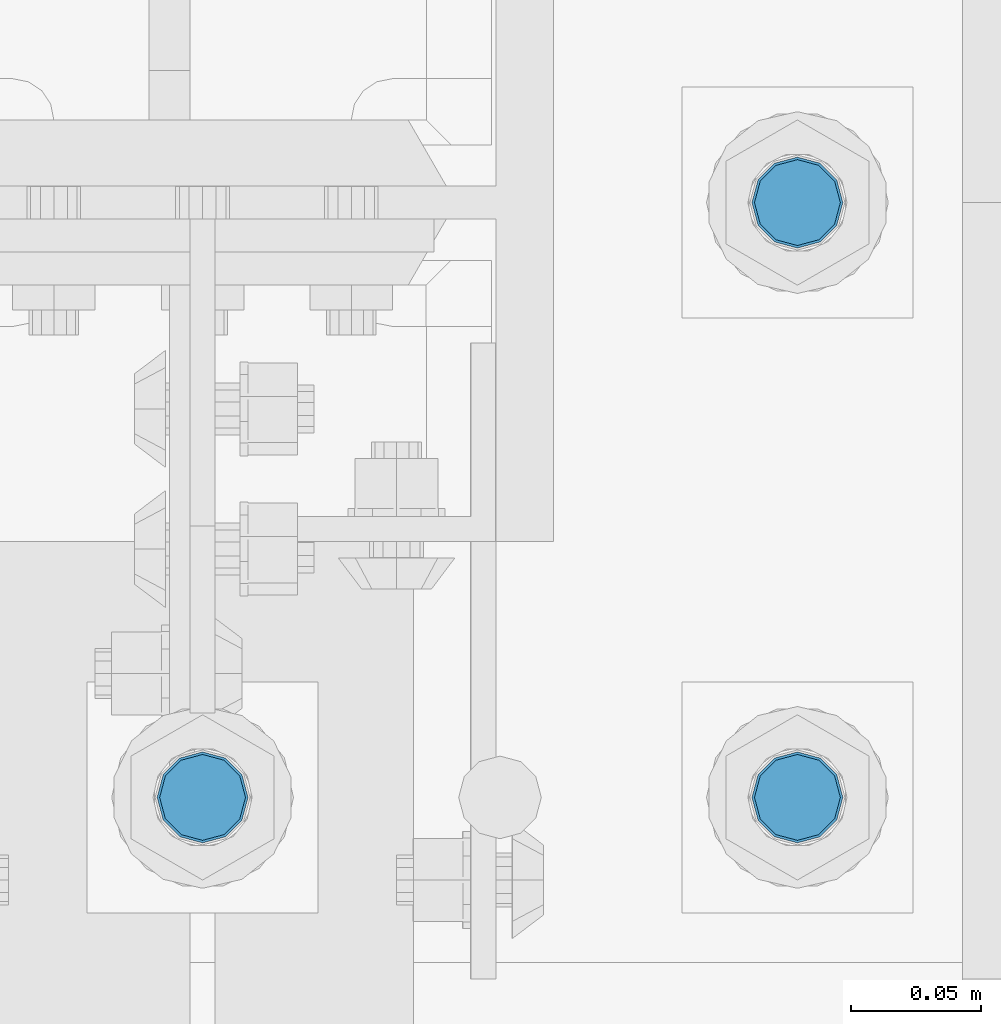
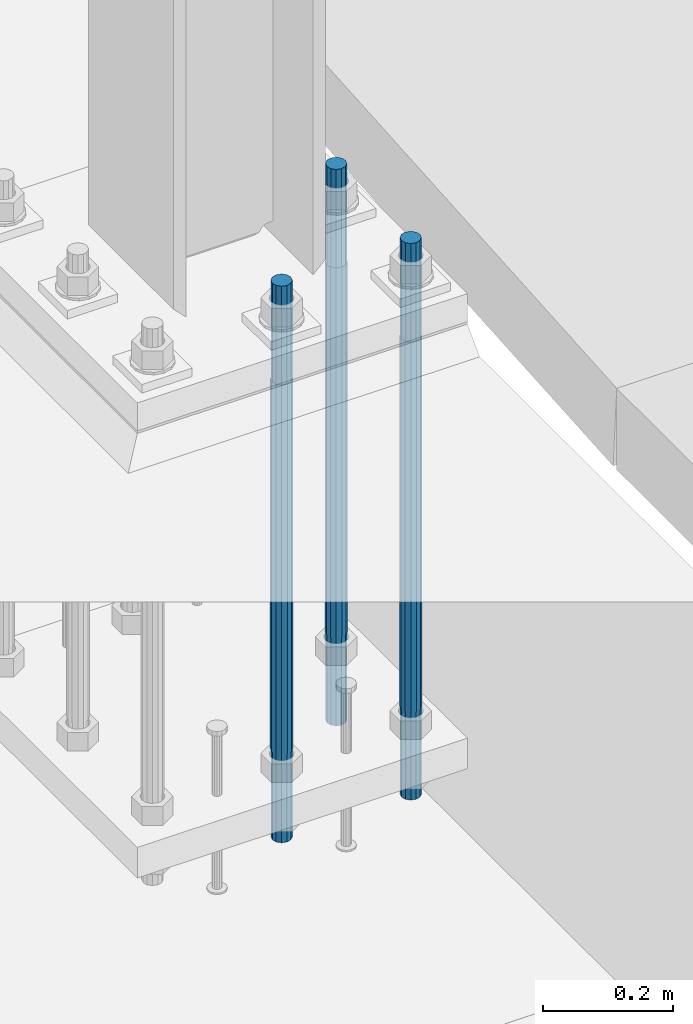
# One storey, part 653 of 1876: 3 columns, 1 element without a shape of its own.
"""IFC2X3 building model written with IfcOpenShell, lengths in millimetres."""

from ifc_helpers import new_model, si_unit, frame, origin_with_axes, place, context, subcontext, project, spatial, faceted_brep, material, type_object, element, aggregate, save


model = new_model("IFC2X3")

# Units and contexts
model_context = context("Model", 3, precision=1e-05, world=origin_with_axes())
body_context = subcontext(model_context, "Body", "Model", "MODEL_VIEW")
ifc_project = project(units=[si_unit("LENGTHUNIT", "METRE", prefix="MILLI"), si_unit("AREAUNIT", "SQUARE_METRE"), si_unit("VOLUMEUNIT", "CUBIC_METRE"), si_unit("MASSUNIT", "GRAM", prefix="KILO"), si_unit("TIMEUNIT", "SECOND"), si_unit("PLANEANGLEUNIT", "RADIAN"), si_unit("SOLIDANGLEUNIT", "STERADIAN"), si_unit("THERMODYNAMICTEMPERATUREUNIT", "DEGREE_CELSIUS"), si_unit("LUMINOUSINTENSITYUNIT", "LUMEN")], contexts=[model_context])

# Site, building, storey
site_placement = place(None, origin_with_axes())
site = spatial("IfcSite", under=ifc_project, at=site_placement, CompositionType="ELEMENT")
building_placement = place(site_placement, origin_with_axes())
building = spatial("IfcBuilding", under=site, at=building_placement, Name="Undefined", CompositionType="ELEMENT")
storey_placement = place(building_placement, origin_with_axes())
storey = spatial("IfcBuildingStorey", under=building, at=storey_placement, Name="Undefined", CompositionType="ELEMENT", Elevation=0.0)

# Assembly, columns
assembly_placement = place(storey_placement, origin_with_axes())
assembly = element("IfcElementAssembly", 1, at=assembly_placement, inside=storey, Name="TEMPLATE", AssemblyPlace="NOTDEFINED", PredefinedType="RIGID_FRAME")
ifc_material = material(Name="STEEL/F1554-GR.105")
column_type = type_object("IfcColumnType", PredefinedType="NOTDEFINED")
column_1_placement = place(assembly_placement, frame((7848.6, -7340.6, 0.0), z_axis=(1.0, 0.0, 0.0), x_axis=(0.0, 0.0, -1.0)))
column_1 = element("IfcColumn", 2, at=column_1_placement, type_object=column_type, material=ifc_material, Name="ANCHOR_BOLTS", context=body_context, shape_type="Brep", body=[
    faceted_brep([(-184.15, -14.2894191624437, 8.25), (-184.15, -8.25, 14.2894191624432), (-184.15, 0.0, 16.5), (-184.15, 8.25, 14.2894191624432), (-184.15, 14.2894191624437, 8.25), (-184.15, 16.5, 0.0), (-184.15, 14.2894191624437, -8.25), (-184.15, 8.25, -14.2894191624432), (-184.15, 0.0, -16.5), (-184.15, -8.25, -14.2894191624432), (-184.15, -14.2894191624437, -8.25), (-184.15, -16.5, 0.0), (0.0, 16.5, 0.0), (0.0, 14.2894191624437, -8.25), (0.0, 8.25, -14.2894191624432), (0.0, 0.0, -16.5), (0.0, -8.25, -14.2894191624432), (0.0, -14.2894191624437, -8.25), (0.0, -16.5, 0.0), (0.0, -14.2894191624437, 8.25), (0.0, -8.25, 14.2894191624432), (0.0, 0.0, 16.5), (0.0, 8.25, 14.2894191624432), (0.0, 14.2894191624437, 8.25), (0.0, -15.1229686135858, 8.73125000000073), (0.0, -8.73124999999999, 15.1229686135848), (0.0, 0.0, 17.4625000000015), (0.0, 8.73124999999999, 15.1229686135848), (0.0, 15.1229686135858, 8.73125000000073), (0.0, 17.4625, 0.0), (0.0, 15.1229686135858, -8.73125000000073), (0.0, 8.73124999999999, -15.1229686135848), (0.0, 0.0, -17.4625000000015), (0.0, -8.73124999999999, -15.1229686135848), (0.0, -15.1229686135857, -8.73125000000073), (0.0, -17.4625, 0.0), (692.15, -17.4624999999996, 0.0), (692.15, -15.1229686135857, 8.73124999999982), (692.15, -8.73124999999982, 15.1229686135857), (692.15, 0.0, 17.4624999999996), (692.15, 8.73124999999982, 15.1229686135857), (692.15, 15.1229686135857, 8.73124999999982), (692.15, 17.4624999999996, 0.0), (692.15, 15.1229686135857, -8.73124999999982), (692.15, 8.73124999999982, -15.1229686135857), (692.15, 0.0, -17.4624999999996), (692.15, -8.73124999999982, -15.1229686135857), (692.15, -15.1229686135857, -8.73124999999982), (692.15, -8.25, 14.2894191624437), (692.15, 0.0, 16.5), (692.15, 8.25, 14.2894191624437), (692.15, 14.2894191624437, 8.25), (692.15, 16.5, 0.0), (692.15, 14.2894191624437, -8.25), (692.15, 8.25, -14.2894191624437), (692.15, 0.0, -16.5), (692.15, -8.25, -14.2894191624437), (692.15, -14.2894191624437, -8.25), (692.15, -16.5, 0.0), (692.15, -14.2894191624437, 8.25), (857.25, -8.25, -14.2894191624437), (857.25, 0.0, -16.5), (857.25, 8.25, -14.2894191624437), (857.25, 14.2894191624437, -8.25), (857.25, 16.5, 0.0), (857.25, 14.2894191624437, 8.25), (857.25, 8.25, 14.2894191624437), (857.25, 0.0, 16.5), (857.25, -8.25, 14.2894191624437), (857.25, -14.2894191624437, 8.25), (857.25, -16.5, 0.0), (857.25, -14.2894191624437, -8.25)], [[[0, 1, 2, 3, 4, 5, 6, 7, 8, 9, 10, 11]], [[6, 5, 12, 13]], [[7, 6, 13, 14]], [[8, 7, 14, 15]], [[9, 8, 15, 16]], [[10, 9, 16, 17]], [[11, 10, 17, 18]], [[0, 11, 18, 19]], [[1, 0, 19, 20]], [[2, 1, 20, 21]], [[3, 2, 21, 22]], [[4, 3, 22, 23]], [[5, 4, 23, 12]], [[24, 25, 26, 27, 28, 29, 30, 31, 32, 33, 34, 35], [22, 21, 20, 19, 18, 17, 16, 15, 14, 13, 12, 23]], [[24, 35, 36, 37]], [[25, 24, 37, 38]], [[26, 25, 38, 39]], [[27, 26, 39, 40]], [[28, 27, 40, 41]], [[29, 28, 41, 42]], [[30, 29, 42, 43]], [[31, 30, 43, 44]], [[32, 31, 44, 45]], [[33, 32, 45, 46]], [[34, 33, 46, 47]], [[35, 34, 47, 36]], [[46, 45, 44, 43, 42, 41, 40, 39, 38, 37, 36, 47], [48, 49, 50, 51, 52, 53, 54, 55, 56, 57, 58, 59]], [[60, 61, 62, 63, 64, 65, 66, 67, 68, 69, 70, 71]], [[68, 67, 49, 48]], [[69, 68, 48, 59]], [[70, 69, 59, 58]], [[71, 70, 58, 57]], [[60, 71, 57, 56]], [[61, 60, 56, 55]], [[62, 61, 55, 54]], [[63, 62, 54, 53]], [[64, 63, 53, 52]], [[65, 64, 52, 51]], [[66, 65, 51, 50]], [[67, 66, 50, 49]]]),
])
column_2_placement = place(assembly_placement, frame((7848.6, -7112.0, 0.0), z_axis=(1.0, 0.0, 0.0), x_axis=(0.0, 0.0, -1.0)))
column_2 = element("IfcColumn", 3, at=column_2_placement, type_object=column_type, material=ifc_material, Name="ANCHOR_BOLTS", context=body_context, shape_type="Brep", body=[
    faceted_brep([(-184.15, -14.2894191624437, 8.25), (-184.15, -8.25, 14.2894191624432), (-184.15, 0.0, 16.5), (-184.15, 8.25, 14.2894191624432), (-184.15, 14.2894191624437, 8.25), (-184.15, 16.5, 0.0), (-184.15, 14.2894191624437, -8.25), (-184.15, 8.25, -14.2894191624432), (-184.15, 0.0, -16.5), (-184.15, -8.25, -14.2894191624432), (-184.15, -14.2894191624437, -8.25), (-184.15, -16.5, 0.0), (0.0, 16.5, 0.0), (0.0, 14.2894191624437, -8.25), (0.0, 8.25, -14.2894191624432), (0.0, 0.0, -16.5), (0.0, -8.25, -14.2894191624432), (0.0, -14.2894191624437, -8.25), (0.0, -16.5, 0.0), (0.0, -14.2894191624437, 8.25), (0.0, -8.25, 14.2894191624432), (0.0, 0.0, 16.5), (0.0, 8.25, 14.2894191624432), (0.0, 14.2894191624437, 8.25), (0.0, -15.1229686135858, 8.73125000000073), (0.0, -8.73124999999999, 15.1229686135848), (0.0, 0.0, 17.4625000000015), (0.0, 8.73124999999999, 15.1229686135848), (0.0, 15.1229686135858, 8.73125000000073), (0.0, 17.4625, 0.0), (0.0, 15.1229686135858, -8.73125000000073), (0.0, 8.73124999999999, -15.1229686135848), (0.0, 0.0, -17.4625000000015), (0.0, -8.73124999999999, -15.1229686135848), (0.0, -15.1229686135857, -8.73125000000073), (0.0, -17.4625, 0.0), (692.15, -17.4624999999996, 0.0), (692.15, -15.1229686135857, 8.73124999999982), (692.15, -8.73124999999982, 15.1229686135857), (692.15, 0.0, 17.4624999999996), (692.15, 8.73124999999982, 15.1229686135857), (692.15, 15.1229686135857, 8.73124999999982), (692.15, 17.4624999999996, 0.0), (692.15, 15.1229686135857, -8.73124999999982), (692.15, 8.73124999999982, -15.1229686135857), (692.15, 0.0, -17.4624999999996), (692.15, -8.73124999999982, -15.1229686135857), (692.15, -15.1229686135857, -8.73124999999982), (692.15, -8.25, 14.2894191624437), (692.15, 0.0, 16.5), (692.15, 8.25, 14.2894191624437), (692.15, 14.2894191624437, 8.25), (692.15, 16.5, 0.0), (692.15, 14.2894191624437, -8.25), (692.15, 8.25, -14.2894191624437), (692.15, 0.0, -16.5), (692.15, -8.25, -14.2894191624437), (692.15, -14.2894191624437, -8.25), (692.15, -16.5, 0.0), (692.15, -14.2894191624437, 8.25), (857.25, -8.25, -14.2894191624437), (857.25, 0.0, -16.5), (857.25, 8.25, -14.2894191624437), (857.25, 14.2894191624437, -8.25), (857.25, 16.5, 0.0), (857.25, 14.2894191624437, 8.25), (857.25, 8.25, 14.2894191624437), (857.25, 0.0, 16.5), (857.25, -8.25, 14.2894191624437), (857.25, -14.2894191624437, 8.25), (857.25, -16.5, 0.0), (857.25, -14.2894191624437, -8.25)], [[[0, 1, 2, 3, 4, 5, 6, 7, 8, 9, 10, 11]], [[6, 5, 12, 13]], [[7, 6, 13, 14]], [[8, 7, 14, 15]], [[9, 8, 15, 16]], [[10, 9, 16, 17]], [[11, 10, 17, 18]], [[0, 11, 18, 19]], [[1, 0, 19, 20]], [[2, 1, 20, 21]], [[3, 2, 21, 22]], [[4, 3, 22, 23]], [[5, 4, 23, 12]], [[24, 25, 26, 27, 28, 29, 30, 31, 32, 33, 34, 35], [22, 21, 20, 19, 18, 17, 16, 15, 14, 13, 12, 23]], [[24, 35, 36, 37]], [[25, 24, 37, 38]], [[26, 25, 38, 39]], [[27, 26, 39, 40]], [[28, 27, 40, 41]], [[29, 28, 41, 42]], [[30, 29, 42, 43]], [[31, 30, 43, 44]], [[32, 31, 44, 45]], [[33, 32, 45, 46]], [[34, 33, 46, 47]], [[35, 34, 47, 36]], [[46, 45, 44, 43, 42, 41, 40, 39, 38, 37, 36, 47], [48, 49, 50, 51, 52, 53, 54, 55, 56, 57, 58, 59]], [[60, 61, 62, 63, 64, 65, 66, 67, 68, 69, 70, 71]], [[68, 67, 49, 48]], [[69, 68, 48, 59]], [[70, 69, 59, 58]], [[71, 70, 58, 57]], [[60, 71, 57, 56]], [[61, 60, 56, 55]], [[62, 61, 55, 54]], [[63, 62, 54, 53]], [[64, 63, 53, 52]], [[65, 64, 52, 51]], [[66, 65, 51, 50]], [[67, 66, 50, 49]]]),
])
column_3_placement = place(assembly_placement, frame((7620.0, -7340.6, 0.0), z_axis=(1.0, 0.0, 0.0), x_axis=(0.0, 0.0, -1.0)))
column_3 = element("IfcColumn", 4, at=column_3_placement, type_object=column_type, material=ifc_material, Name="ANCHOR_BOLTS", context=body_context, shape_type="Brep", body=[
    faceted_brep([(-184.15, -14.2894191624437, 8.25), (-184.15, -8.25, 14.2894191624432), (-184.15, 0.0, 16.5), (-184.15, 8.25, 14.2894191624432), (-184.15, 14.2894191624437, 8.25), (-184.15, 16.5, 0.0), (-184.15, 14.2894191624437, -8.25), (-184.15, 8.25, -14.2894191624432), (-184.15, 0.0, -16.5), (-184.15, -8.25, -14.2894191624432), (-184.15, -14.2894191624437, -8.25), (-184.15, -16.5, 0.0), (0.0, 16.5, 0.0), (0.0, 14.2894191624437, -8.25), (0.0, 8.25, -14.2894191624432), (0.0, 0.0, -16.5), (0.0, -8.25, -14.2894191624432), (0.0, -14.2894191624437, -8.25), (0.0, -16.5, 0.0), (0.0, -14.2894191624437, 8.25), (0.0, -8.25, 14.2894191624432), (0.0, 0.0, 16.5), (0.0, 8.25, 14.2894191624432), (0.0, 14.2894191624437, 8.25), (0.0, -15.1229686135858, 8.73125000000073), (0.0, -8.73124999999999, 15.1229686135848), (0.0, 0.0, 17.4625000000015), (0.0, 8.73124999999999, 15.1229686135848), (0.0, 15.1229686135858, 8.73125000000073), (0.0, 17.4625, 0.0), (0.0, 15.1229686135858, -8.73125000000073), (0.0, 8.73124999999999, -15.1229686135848), (0.0, 0.0, -17.4625000000015), (0.0, -8.73124999999999, -15.1229686135848), (0.0, -15.1229686135857, -8.73125000000073), (0.0, -17.4625, 0.0), (692.15, -17.4624999999996, 0.0), (692.15, -15.1229686135857, 8.73124999999982), (692.15, -8.73124999999982, 15.1229686135857), (692.15, 0.0, 17.4624999999996), (692.15, 8.73124999999982, 15.1229686135857), (692.15, 15.1229686135857, 8.73124999999982), (692.15, 17.4624999999996, 0.0), (692.15, 15.1229686135857, -8.73124999999982), (692.15, 8.73124999999982, -15.1229686135857), (692.15, 0.0, -17.4624999999996), (692.15, -8.73124999999982, -15.1229686135857), (692.15, -15.1229686135857, -8.73124999999982), (692.15, -8.25, 14.2894191624437), (692.15, 0.0, 16.5), (692.15, 8.25, 14.2894191624437), (692.15, 14.2894191624437, 8.25), (692.15, 16.5, 0.0), (692.15, 14.2894191624437, -8.25), (692.15, 8.25, -14.2894191624437), (692.15, 0.0, -16.5), (692.15, -8.25, -14.2894191624437), (692.15, -14.2894191624437, -8.25), (692.15, -16.5, 0.0), (692.15, -14.2894191624437, 8.25), (857.25, -8.25, -14.2894191624437), (857.25, 0.0, -16.5), (857.25, 8.25, -14.2894191624437), (857.25, 14.2894191624437, -8.25), (857.25, 16.5, 0.0), (857.25, 14.2894191624437, 8.25), (857.25, 8.25, 14.2894191624437), (857.25, 0.0, 16.5), (857.25, -8.25, 14.2894191624437), (857.25, -14.2894191624437, 8.25), (857.25, -16.5, 0.0), (857.25, -14.2894191624437, -8.25)], [[[0, 1, 2, 3, 4, 5, 6, 7, 8, 9, 10, 11]], [[6, 5, 12, 13]], [[7, 6, 13, 14]], [[8, 7, 14, 15]], [[9, 8, 15, 16]], [[10, 9, 16, 17]], [[11, 10, 17, 18]], [[0, 11, 18, 19]], [[1, 0, 19, 20]], [[2, 1, 20, 21]], [[3, 2, 21, 22]], [[4, 3, 22, 23]], [[5, 4, 23, 12]], [[24, 25, 26, 27, 28, 29, 30, 31, 32, 33, 34, 35], [22, 21, 20, 19, 18, 17, 16, 15, 14, 13, 12, 23]], [[24, 35, 36, 37]], [[25, 24, 37, 38]], [[26, 25, 38, 39]], [[27, 26, 39, 40]], [[28, 27, 40, 41]], [[29, 28, 41, 42]], [[30, 29, 42, 43]], [[31, 30, 43, 44]], [[32, 31, 44, 45]], [[33, 32, 45, 46]], [[34, 33, 46, 47]], [[35, 34, 47, 36]], [[46, 45, 44, 43, 42, 41, 40, 39, 38, 37, 36, 47], [48, 49, 50, 51, 52, 53, 54, 55, 56, 57, 58, 59]], [[60, 61, 62, 63, 64, 65, 66, 67, 68, 69, 70, 71]], [[68, 67, 49, 48]], [[69, 68, 48, 59]], [[70, 69, 59, 58]], [[71, 70, 58, 57]], [[60, 71, 57, 56]], [[61, 60, 56, 55]], [[62, 61, 55, 54]], [[63, 62, 54, 53]], [[64, 63, 53, 52]], [[65, 64, 52, 51]], [[66, 65, 51, 50]], [[67, 66, 50, 49]]]),
])
aggregate(assembly, [column_1, column_2, column_3])

save(model, "model.ifc")
